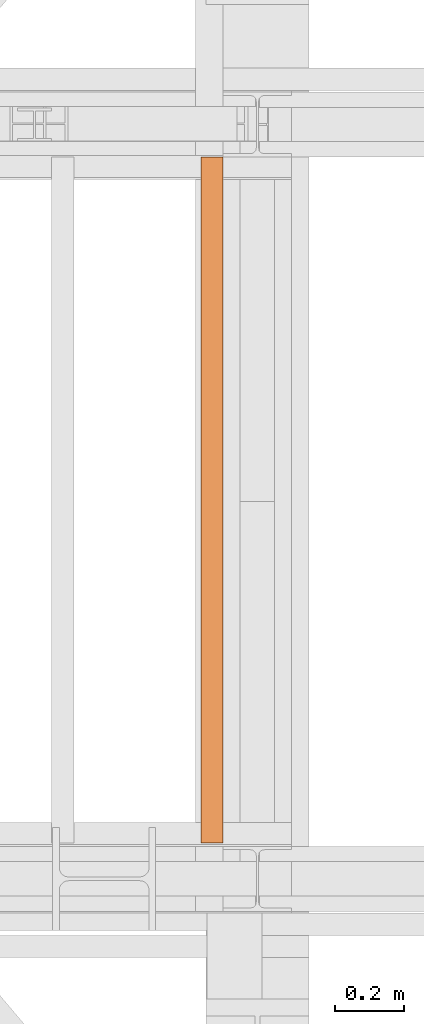
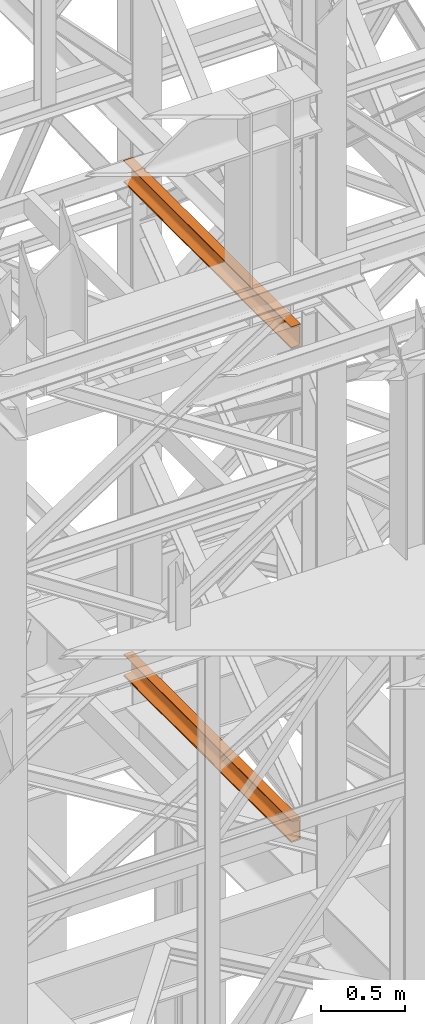
# One storey, part 160 of 208: 2 proxies.
"""IFC2X3 building model written with IfcOpenShell, lengths in millimetres."""

from ifc_helpers import new_model, entity, si_unit, converted_unit, frame, origin, origin_with_axes, place, context, subcontext, project, spatial, faceted_brep, element, save


model = new_model("IFC2X3")

# Units and contexts
model_context = context("Model", 3, precision=1e-05, world=origin())
plan_context = context("Plan", 3, precision=1e-05, world=origin())
body_context = subcontext(model_context, "Body", "Model", "MODEL_VIEW")
ifc_project = project(units=[si_unit("LENGTHUNIT", "METRE", prefix="MILLI"), converted_unit("PLANEANGLEUNIT", "DEGREE", entity("IfcPlaneAngleMeasure", 0.0174532925199433), si_unit("PLANEANGLEUNIT", "RADIAN"), dimensions=[0, 0, 0, 0, 0, 0, 0]), si_unit("AREAUNIT", "SQUARE_METRE"), si_unit("VOLUMEUNIT", "CUBIC_METRE")], contexts=[model_context, plan_context])

# Building, storey
building_placement = place(None, origin())
building = spatial("IfcBuilding", under=ifc_project, at=building_placement, CompositionType="COMPLEX")
storey_placement = place(building_placement, origin_with_axes())
storey = spatial("IfcBuildingStorey", under=building, at=storey_placement, Name="Geschoss", CompositionType="ELEMENT")

# Proxies
proxy_1_placement = place(storey_placement, frame((5328.254967038551, -15857.57439274273, 9109.989999999998), z_axis=(0.0, 0.0, 1.0), x_axis=(1.0, 0.0, 0.0)))
element("IfcBuildingElementProxy", 1, at=proxy_1_placement, inside=storey, context=body_context, shape_type="Brep", body=[
    faceted_brep([(65.01000000000022, 2000.009997019768, 160.0100000000002), (65.01000000000204, 0.01000000000021828, 160.0100000000002), (0.01000000000203727, 0.01000000000021828, 160.0100000000002), (0.01000000000021828, 2000.009997019768, 160.0100000000002), (0.01000000000021828, 2000.009997019768, 160.0100000000002), (0.01000000000203727, 0.01000000000021828, 160.0100000000002), (0.01000000000203727, 0.01000000000021828, 156.8875719297539), (0.01000000000021828, 2000.009997019768, 156.8875719297539), (0.01000000000021828, 2000.009997019768, 156.8875719297539), (0.01000000000203727, 0.01000000000021828, 156.8875719297539), (0.2527365771748009, 0.01000000000021828, 155.2717110918293), (0.2527365771729819, 2000.009997019768, 155.2717110918293), (0.2527365771729819, 2000.009997019768, 155.2717110918293), (0.2527365771748009, 0.01000000000021828, 155.2717110918293), (0.9594677141431021, 0.01000000000021828, 153.7984655565542), (0.959467714144921, 2000.009997019768, 153.7984655565542), (0.959467714144921, 2000.009997019768, 153.7984655565542), (0.9594677141431021, 0.01000000000021828, 153.7984655565542), (2.067848361533834, 0.01000000000021828, 152.5978732961266), (2.067848361532015, 2000.009997019768, 152.5978732961266), (2.067848361532015, 2000.009997019768, 152.5978732961266), (2.067848361533834, 0.01000000000021828, 152.5978732961266), (3.480043588519038, 0.01000000000021828, 151.7759086082897), (3.480043588517219, 2000.009997019768, 151.7759086082897), (3.480043588517219, 2000.009997019768, 151.7759086082897), (3.480043588519038, 0.01000000000021828, 151.7759086082897), (5.071401277447876, 0.01000000000021828, 151.4050878978051), (5.071401277446057, 2000.009997019768, 151.4050878978051), (5.071401277446057, 2000.009997019768, 151.4050878978051), (5.071401277447876, 0.01000000000021828, 151.4050878978051), (47.84732483397238, 0.01000000000021828, 147.9830140132835), (47.84732483397056, 2000.009997019768, 147.9830140132835), (47.84732483397056, 2000.009997019768, 147.9830140132835), (47.84732483397238, 0.01000000000021828, 147.9830140132835), (50.81159179199312, 0.01000000000021828, 147.318026761528), (50.8115917919913, 2000.009997019768, 147.318026761528), (50.8115917919913, 2000.009997019768, 147.318026761528), (50.81159179199312, 0.01000000000021828, 147.318026761528), (53.58138040071208, 0.01000000000021828, 145.7058782528511), (53.5813804007139, 2000.009997019768, 145.7058782528511), (53.5813804007139, 2000.009997019768, 145.7058782528511), (53.58138040071208, 0.01000000000021828, 145.7058782528511), (55.69737981845537, 0.01000000000021828, 143.4138384829421), (55.69737981845356, 2000.009997019768, 143.4138384829421), (55.69737981845356, 2000.009997019768, 143.4138384829421), (55.69737981845537, 0.01000000000021828, 143.4138384829421), (57.04659380721569, 0.01000000000021828, 140.6012788246917), (57.04659380721387, 2000.009997019768, 140.6012788246917), (57.04659380721387, 2000.009997019768, 140.6012788246917), (57.04659380721569, 0.01000000000021828, 140.6012788246917), (57.51000000000204, 0.01000000000021828, 137.5164535886543), (57.51000000000022, 2000.009997019768, 137.5164535886543), (57.51000000000022, 2000.009997019768, 137.5164535886543), (57.51000000000204, 0.01000000000021828, 137.5164535886543), (57.51000000000204, 0.01000000000021828, 22.503546411348), (57.51000000000022, 2000.009997019768, 22.503546411348), (57.51000000000022, 2000.009997019768, 22.503546411348), (57.51000000000204, 0.01000000000021828, 22.503546411348), (57.04659380721569, 0.01000000000021828, 19.41872117530875), (57.04659380721387, 2000.009997019768, 19.41872117530875), (57.04659380721387, 2000.009997019768, 19.41872117530875), (57.04659380721569, 0.01000000000021828, 19.41872117530875), (55.69737981845537, 0.01000000000021828, 16.60616151705835), (55.69737981845356, 2000.009997019768, 16.60616151705835), (55.69737981845356, 2000.009997019768, 16.60616151705835), (55.69737981845537, 0.01000000000021828, 16.60616151705835), (53.58138040071208, 0.01000000000021828, 14.31412174714933), (53.5813804007139, 2000.009997019768, 14.31412174714933), (53.5813804007139, 2000.009997019768, 14.31412174714933), (53.58138040071208, 0.01000000000021828, 14.31412174714933), (50.88537133101636, 0.01000000000021828, 12.74491643400688), (50.88537133101818, 2000.009997019768, 12.74491643400688), (50.88537133101818, 2000.009997019768, 12.74491643400688), (50.88537133101636, 0.01000000000021828, 12.74491643400688), (47.84732483397238, 0.01000000000021828, 12.03698598671872), (47.84732483397056, 2000.009997019768, 12.03698598671872), (47.84732483397056, 2000.009997019768, 12.03698598671872), (47.84732483397238, 0.01000000000021828, 12.03698598671872), (5.071401277447876, 0.01000000000021828, 8.614912102195376), (5.071401277446057, 2000.009997019768, 8.614912102195376), (5.071401277446057, 2000.009997019768, 8.614912102195376), (5.071401277447876, 0.01000000000021828, 8.614912102195376), (3.480043588519038, 0.01000000000021828, 8.244091391710754), (3.480043588517219, 2000.009997019768, 8.244091391710754), (3.480043588517219, 2000.009997019768, 8.244091391710754), (3.480043588519038, 0.01000000000021828, 8.244091391710754), (2.067848361533834, 0.01000000000021828, 7.422126703873801), (2.067848361532015, 2000.009997019768, 7.422126703873801), (2.067848361532015, 2000.009997019768, 7.422126703873801), (2.067848361533834, 0.01000000000021828, 7.422126703873801), (0.9594677141431021, 0.01000000000021828, 6.221534443446217), (0.959467714144921, 2000.009997019768, 6.221534443446217), (0.959467714144921, 2000.009997019768, 6.221534443446217), (0.9594677141431021, 0.01000000000021828, 6.221534443446217), (0.2527365771748009, 0.01000000000021828, 4.748288908172981), (0.2527365771729819, 2000.009997019768, 4.748288908172981), (0.2527365771729819, 2000.009997019768, 4.748288908172981), (0.2527365771748009, 0.01000000000021828, 4.748288908172981), (0.01000000000203727, 0.01000000000021828, 0.01000000000021828), (0.01000000000021828, 2000.009997019768, 0.01000000000021828), (0.01000000000021828, 2000.009997019768, 0.01000000000021828), (0.01000000000203727, 0.01000000000021828, 0.01000000000021828), (65.01000000000204, 0.01000000000021828, 0.01000000000021828), (65.01000000000022, 2000.009997019768, 0.01000000000021828), (65.01000000000022, 2000.009997019768, 0.01000000000021828), (65.01000000000204, 0.01000000000021828, 0.01000000000021828), (65.01000000000204, 0.01000000000021828, 160.0100000000002), (65.01000000000022, 2000.009997019768, 160.0100000000002), (65.01000000000022, 2000.009997019768, 160.0100000000002), (0.01000000000021828, 2000.009997019768, 160.0100000000002), (0.01000000000021828, 2000.009997019768, 156.8875719297539), (0.2527365771729819, 2000.009997019768, 155.2717110918293), (0.959467714144921, 2000.009997019768, 153.7984655565542), (2.067848361532015, 2000.009997019768, 152.5978732961266), (3.480043588517219, 2000.009997019768, 151.7759086082897), (5.071401277446057, 2000.009997019768, 151.4050878978051), (47.84732483397056, 2000.009997019768, 147.9830140132835), (50.8115917919913, 2000.009997019768, 147.318026761528), (53.5813804007139, 2000.009997019768, 145.7058782528511), (55.69737981845356, 2000.009997019768, 143.4138384829421), (57.04659380721387, 2000.009997019768, 140.6012788246917), (57.51000000000022, 2000.009997019768, 137.5164535886543), (57.51000000000022, 2000.009997019768, 22.503546411348), (57.04659380721387, 2000.009997019768, 19.41872117530875), (55.69737981845356, 2000.009997019768, 16.60616151705835), (53.5813804007139, 2000.009997019768, 14.31412174714933), (50.88537133101818, 2000.009997019768, 12.74491643400688), (47.84732483397056, 2000.009997019768, 12.03698598671872), (5.071401277446057, 2000.009997019768, 8.614912102195376), (3.480043588517219, 2000.009997019768, 8.244091391710754), (2.067848361532015, 2000.009997019768, 7.422126703873801), (0.959467714144921, 2000.009997019768, 6.221534443446217), (0.2527365771729819, 2000.009997019768, 4.748288908172981), (0.01000000000021828, 2000.009997019768, 0.01000000000021828), (65.01000000000022, 2000.009997019768, 0.01000000000021828), (65.01000000000204, 0.01000000000021828, 160.0100000000002), (65.01000000000204, 0.01000000000021828, 0.01000000000021828), (0.01000000000203727, 0.01000000000021828, 0.01000000000021828), (0.2527365771748009, 0.01000000000021828, 4.748288908172981), (0.9594677141431021, 0.01000000000021828, 6.221534443446217), (2.067848361533834, 0.01000000000021828, 7.422126703873801), (3.480043588519038, 0.01000000000021828, 8.244091391710754), (5.071401277447876, 0.01000000000021828, 8.614912102195376), (47.84732483397238, 0.01000000000021828, 12.03698598671872), (50.88537133101636, 0.01000000000021828, 12.74491643400688), (53.58138040071208, 0.01000000000021828, 14.31412174714933), (55.69737981845537, 0.01000000000021828, 16.60616151705835), (57.04659380721569, 0.01000000000021828, 19.41872117530875), (57.51000000000204, 0.01000000000021828, 22.503546411348), (57.51000000000204, 0.01000000000021828, 137.5164535886543), (57.04659380721569, 0.01000000000021828, 140.6012788246917), (55.69737981845537, 0.01000000000021828, 143.4138384829421), (53.58138040071208, 0.01000000000021828, 145.7058782528511), (50.81159179199312, 0.01000000000021828, 147.318026761528), (47.84732483397238, 0.01000000000021828, 147.9830140132835), (5.071401277447876, 0.01000000000021828, 151.4050878978051), (3.480043588519038, 0.01000000000021828, 151.7759086082897), (2.067848361533834, 0.01000000000021828, 152.5978732961266), (0.9594677141431021, 0.01000000000021828, 153.7984655565542), (0.2527365771748009, 0.01000000000021828, 155.2717110918293), (0.01000000000203727, 0.01000000000021828, 156.8875719297539), (0.01000000000203727, 0.01000000000021828, 160.0100000000002)], [[[0, 1, 2, 3]], [[4, 5, 6, 7]], [[8, 9, 10, 11]], [[12, 13, 14, 15]], [[16, 17, 18, 19]], [[20, 21, 22, 23]], [[24, 25, 26, 27]], [[28, 29, 30, 31]], [[32, 33, 34, 35]], [[36, 37, 38, 39]], [[40, 41, 42, 43]], [[44, 45, 46, 47]], [[48, 49, 50, 51]], [[52, 53, 54, 55]], [[56, 57, 58, 59]], [[60, 61, 62, 63]], [[64, 65, 66, 67]], [[68, 69, 70, 71]], [[72, 73, 74, 75]], [[76, 77, 78, 79]], [[80, 81, 82, 83]], [[84, 85, 86, 87]], [[88, 89, 90, 91]], [[92, 93, 94, 95]], [[96, 97, 98, 99]], [[100, 101, 102, 103]], [[104, 105, 106, 107]], [[108, 109, 110, 111, 112, 113, 114, 115, 116, 117, 118, 119, 120, 121, 122, 123, 124, 125, 126, 127, 128, 129, 130, 131, 132, 133, 134]], [[135, 136, 137, 138, 139, 140, 141, 142, 143, 144, 145, 146, 147, 148, 149, 150, 151, 152, 153, 154, 155, 156, 157, 158, 159, 160, 161]]], orient=[[False], [False], [False], [False], [False], [False], [False], [False], [False], [False], [False], [False], [False], [False], [False], [False], [False], [False], [False], [False], [False], [False], [False], [False], [False], [False], [False], [False], [False]]),
])
proxy_2_placement = place(storey_placement, frame((5328.254967038551, -15857.57439274273, 5518.360005364418), z_axis=(0.0, 0.0, 1.0), x_axis=(1.0, 0.0, 0.0)))
element("IfcBuildingElementProxy", 2, at=proxy_2_placement, inside=storey, context=body_context, shape_type="Brep", body=[
    faceted_brep([(65.01000000000022, 2000.009997019768, 160.0100000000002), (65.01000000000204, 0.01000000000021828, 160.0100000000002), (0.01000000000203727, 0.01000000000021828, 160.0100000000002), (0.01000000000021828, 2000.009997019768, 160.0100000000002), (0.01000000000021828, 2000.009997019768, 160.0100000000002), (0.01000000000203727, 0.01000000000021828, 160.0100000000002), (0.01000000000203727, 0.01000000000021828, 156.8875719297539), (0.01000000000021828, 2000.009997019768, 156.8875719297539), (0.01000000000021828, 2000.009997019768, 156.8875719297539), (0.01000000000203727, 0.01000000000021828, 156.8875719297539), (0.2527365771748009, 0.01000000000021828, 155.2717110918293), (0.2527365771729819, 2000.009997019768, 155.2717110918293), (0.2527365771729819, 2000.009997019768, 155.2717110918293), (0.2527365771748009, 0.01000000000021828, 155.2717110918293), (0.9594677141431021, 0.01000000000021828, 153.7984655565542), (0.959467714144921, 2000.009997019768, 153.7984655565542), (0.959467714144921, 2000.009997019768, 153.7984655565542), (0.9594677141431021, 0.01000000000021828, 153.7984655565542), (2.067848361533834, 0.01000000000021828, 152.5978732961266), (2.067848361532015, 2000.009997019768, 152.5978732961266), (2.067848361532015, 2000.009997019768, 152.5978732961266), (2.067848361533834, 0.01000000000021828, 152.5978732961266), (3.480043588519038, 0.01000000000021828, 151.7759086082897), (3.480043588517219, 2000.009997019768, 151.7759086082897), (3.480043588517219, 2000.009997019768, 151.7759086082897), (3.480043588519038, 0.01000000000021828, 151.7759086082897), (5.071401277447876, 0.01000000000021828, 151.4050878978051), (5.071401277446057, 2000.009997019768, 151.4050878978051), (5.071401277446057, 2000.009997019768, 151.4050878978051), (5.071401277447876, 0.01000000000021828, 151.4050878978051), (47.84732483397238, 0.01000000000021828, 147.9830140132835), (47.84732483397056, 2000.009997019768, 147.9830140132835), (47.84732483397056, 2000.009997019768, 147.9830140132835), (47.84732483397238, 0.01000000000021828, 147.9830140132835), (50.81159179199312, 0.01000000000021828, 147.318026761528), (50.8115917919913, 2000.009997019768, 147.318026761528), (50.8115917919913, 2000.009997019768, 147.318026761528), (50.81159179199312, 0.01000000000021828, 147.318026761528), (53.58138040071208, 0.01000000000021828, 145.7058782528511), (53.5813804007139, 2000.009997019768, 145.7058782528511), (53.5813804007139, 2000.009997019768, 145.7058782528511), (53.58138040071208, 0.01000000000021828, 145.7058782528511), (55.69737981845537, 0.01000000000021828, 143.4138384829421), (55.69737981845356, 2000.009997019768, 143.4138384829421), (55.69737981845356, 2000.009997019768, 143.4138384829421), (55.69737981845537, 0.01000000000021828, 143.4138384829421), (57.04659380721569, 0.01000000000021828, 140.6012788246917), (57.04659380721387, 2000.009997019768, 140.6012788246917), (57.04659380721387, 2000.009997019768, 140.6012788246917), (57.04659380721569, 0.01000000000021828, 140.6012788246917), (57.51000000000204, 0.01000000000021828, 137.5164535886543), (57.51000000000022, 2000.009997019768, 137.5164535886543), (57.51000000000022, 2000.009997019768, 137.5164535886543), (57.51000000000204, 0.01000000000021828, 137.5164535886543), (57.51000000000204, 0.01000000000021828, 22.503546411348), (57.51000000000022, 2000.009997019768, 22.503546411348), (57.51000000000022, 2000.009997019768, 22.503546411348), (57.51000000000204, 0.01000000000021828, 22.503546411348), (57.04659380721569, 0.01000000000021828, 19.41872117530875), (57.04659380721387, 2000.009997019768, 19.41872117530875), (57.04659380721387, 2000.009997019768, 19.41872117530875), (57.04659380721569, 0.01000000000021828, 19.41872117530875), (55.69737981845537, 0.01000000000021828, 16.60616151705835), (55.69737981845356, 2000.009997019768, 16.60616151705835), (55.69737981845356, 2000.009997019768, 16.60616151705835), (55.69737981845537, 0.01000000000021828, 16.60616151705835), (53.58138040071208, 0.01000000000021828, 14.31412174714933), (53.5813804007139, 2000.009997019768, 14.31412174714933), (53.5813804007139, 2000.009997019768, 14.31412174714933), (53.58138040071208, 0.01000000000021828, 14.31412174714933), (50.88537133101636, 0.01000000000021828, 12.74491643400688), (50.88537133101818, 2000.009997019768, 12.74491643400688), (50.88537133101818, 2000.009997019768, 12.74491643400688), (50.88537133101636, 0.01000000000021828, 12.74491643400688), (47.84732483397238, 0.01000000000021828, 12.03698598671872), (47.84732483397056, 2000.009997019768, 12.03698598671872), (47.84732483397056, 2000.009997019768, 12.03698598671872), (47.84732483397238, 0.01000000000021828, 12.03698598671872), (5.071401277447876, 0.01000000000021828, 8.614912102195376), (5.071401277446057, 2000.009997019768, 8.614912102195376), (5.071401277446057, 2000.009997019768, 8.614912102195376), (5.071401277447876, 0.01000000000021828, 8.614912102195376), (3.480043588519038, 0.01000000000021828, 8.244091391710754), (3.480043588517219, 2000.009997019768, 8.244091391710754), (3.480043588517219, 2000.009997019768, 8.244091391710754), (3.480043588519038, 0.01000000000021828, 8.244091391710754), (2.067848361533834, 0.01000000000021828, 7.422126703873801), (2.067848361532015, 2000.009997019768, 7.422126703873801), (2.067848361532015, 2000.009997019768, 7.422126703873801), (2.067848361533834, 0.01000000000021828, 7.422126703873801), (0.9594677141431021, 0.01000000000021828, 6.221534443446217), (0.959467714144921, 2000.009997019768, 6.221534443446217), (0.959467714144921, 2000.009997019768, 6.221534443446217), (0.9594677141431021, 0.01000000000021828, 6.221534443446217), (0.2527365771748009, 0.01000000000021828, 4.748288908172981), (0.2527365771729819, 2000.009997019768, 4.748288908172981), (0.2527365771729819, 2000.009997019768, 4.748288908172981), (0.2527365771748009, 0.01000000000021828, 4.748288908172981), (0.01000000000203727, 0.01000000000021828, 0.01000000000021828), (0.01000000000021828, 2000.009997019768, 0.01000000000021828), (0.01000000000021828, 2000.009997019768, 0.01000000000021828), (0.01000000000203727, 0.01000000000021828, 0.01000000000021828), (65.01000000000204, 0.01000000000021828, 0.01000000000021828), (65.01000000000022, 2000.009997019768, 0.01000000000021828), (65.01000000000022, 2000.009997019768, 0.01000000000021828), (65.01000000000204, 0.01000000000021828, 0.01000000000021828), (65.01000000000204, 0.01000000000021828, 160.0100000000002), (65.01000000000022, 2000.009997019768, 160.0100000000002), (65.01000000000022, 2000.009997019768, 160.0100000000002), (0.01000000000021828, 2000.009997019768, 160.0100000000002), (0.01000000000021828, 2000.009997019768, 156.8875719297539), (0.2527365771729819, 2000.009997019768, 155.2717110918293), (0.959467714144921, 2000.009997019768, 153.7984655565542), (2.067848361532015, 2000.009997019768, 152.5978732961266), (3.480043588517219, 2000.009997019768, 151.7759086082897), (5.071401277446057, 2000.009997019768, 151.4050878978051), (47.84732483397056, 2000.009997019768, 147.9830140132835), (50.8115917919913, 2000.009997019768, 147.318026761528), (53.5813804007139, 2000.009997019768, 145.7058782528511), (55.69737981845356, 2000.009997019768, 143.4138384829421), (57.04659380721387, 2000.009997019768, 140.6012788246917), (57.51000000000022, 2000.009997019768, 137.5164535886543), (57.51000000000022, 2000.009997019768, 22.503546411348), (57.04659380721387, 2000.009997019768, 19.41872117530875), (55.69737981845356, 2000.009997019768, 16.60616151705835), (53.5813804007139, 2000.009997019768, 14.31412174714933), (50.88537133101818, 2000.009997019768, 12.74491643400688), (47.84732483397056, 2000.009997019768, 12.03698598671872), (5.071401277446057, 2000.009997019768, 8.614912102195376), (3.480043588517219, 2000.009997019768, 8.244091391710754), (2.067848361532015, 2000.009997019768, 7.422126703873801), (0.959467714144921, 2000.009997019768, 6.221534443446217), (0.2527365771729819, 2000.009997019768, 4.748288908172981), (0.01000000000021828, 2000.009997019768, 0.01000000000021828), (65.01000000000022, 2000.009997019768, 0.01000000000021828), (65.01000000000204, 0.01000000000021828, 160.0100000000002), (65.01000000000204, 0.01000000000021828, 0.01000000000021828), (0.01000000000203727, 0.01000000000021828, 0.01000000000021828), (0.2527365771748009, 0.01000000000021828, 4.748288908172981), (0.9594677141431021, 0.01000000000021828, 6.221534443446217), (2.067848361533834, 0.01000000000021828, 7.422126703873801), (3.480043588519038, 0.01000000000021828, 8.244091391710754), (5.071401277447876, 0.01000000000021828, 8.614912102195376), (47.84732483397238, 0.01000000000021828, 12.03698598671872), (50.88537133101636, 0.01000000000021828, 12.74491643400688), (53.58138040071208, 0.01000000000021828, 14.31412174714933), (55.69737981845537, 0.01000000000021828, 16.60616151705835), (57.04659380721569, 0.01000000000021828, 19.41872117530875), (57.51000000000204, 0.01000000000021828, 22.503546411348), (57.51000000000204, 0.01000000000021828, 137.5164535886543), (57.04659380721569, 0.01000000000021828, 140.6012788246917), (55.69737981845537, 0.01000000000021828, 143.4138384829421), (53.58138040071208, 0.01000000000021828, 145.7058782528511), (50.81159179199312, 0.01000000000021828, 147.318026761528), (47.84732483397238, 0.01000000000021828, 147.9830140132835), (5.071401277447876, 0.01000000000021828, 151.4050878978051), (3.480043588519038, 0.01000000000021828, 151.7759086082897), (2.067848361533834, 0.01000000000021828, 152.5978732961266), (0.9594677141431021, 0.01000000000021828, 153.7984655565542), (0.2527365771748009, 0.01000000000021828, 155.2717110918293), (0.01000000000203727, 0.01000000000021828, 156.8875719297539), (0.01000000000203727, 0.01000000000021828, 160.0100000000002)], [[[0, 1, 2, 3]], [[4, 5, 6, 7]], [[8, 9, 10, 11]], [[12, 13, 14, 15]], [[16, 17, 18, 19]], [[20, 21, 22, 23]], [[24, 25, 26, 27]], [[28, 29, 30, 31]], [[32, 33, 34, 35]], [[36, 37, 38, 39]], [[40, 41, 42, 43]], [[44, 45, 46, 47]], [[48, 49, 50, 51]], [[52, 53, 54, 55]], [[56, 57, 58, 59]], [[60, 61, 62, 63]], [[64, 65, 66, 67]], [[68, 69, 70, 71]], [[72, 73, 74, 75]], [[76, 77, 78, 79]], [[80, 81, 82, 83]], [[84, 85, 86, 87]], [[88, 89, 90, 91]], [[92, 93, 94, 95]], [[96, 97, 98, 99]], [[100, 101, 102, 103]], [[104, 105, 106, 107]], [[108, 109, 110, 111, 112, 113, 114, 115, 116, 117, 118, 119, 120, 121, 122, 123, 124, 125, 126, 127, 128, 129, 130, 131, 132, 133, 134]], [[135, 136, 137, 138, 139, 140, 141, 142, 143, 144, 145, 146, 147, 148, 149, 150, 151, 152, 153, 154, 155, 156, 157, 158, 159, 160, 161]]], orient=[[False], [False], [False], [False], [False], [False], [False], [False], [False], [False], [False], [False], [False], [False], [False], [False], [False], [False], [False], [False], [False], [False], [False], [False], [False], [False], [False], [False], [False]]),
])

save(model, "model.ifc")
